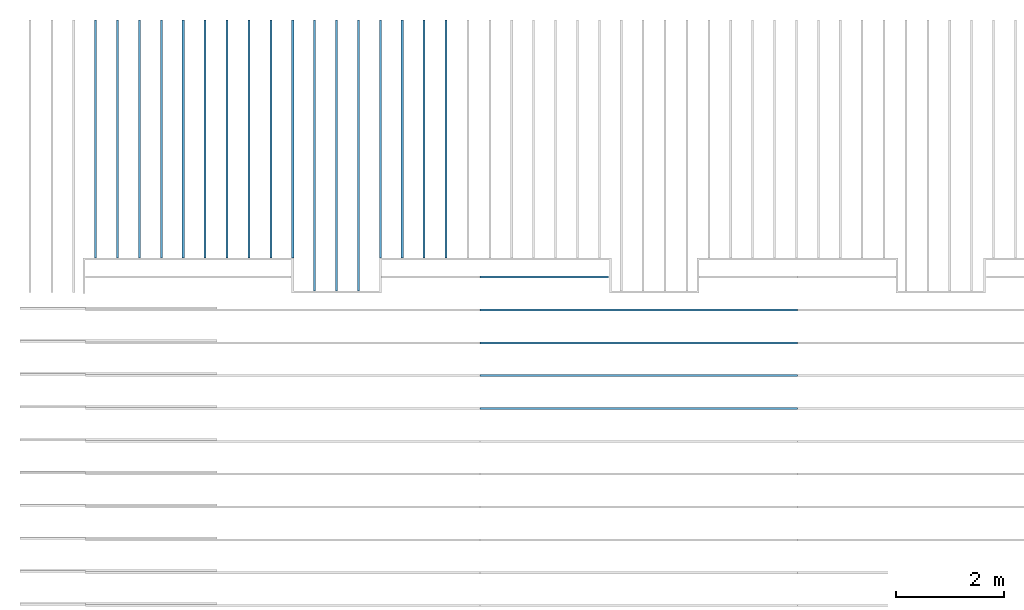
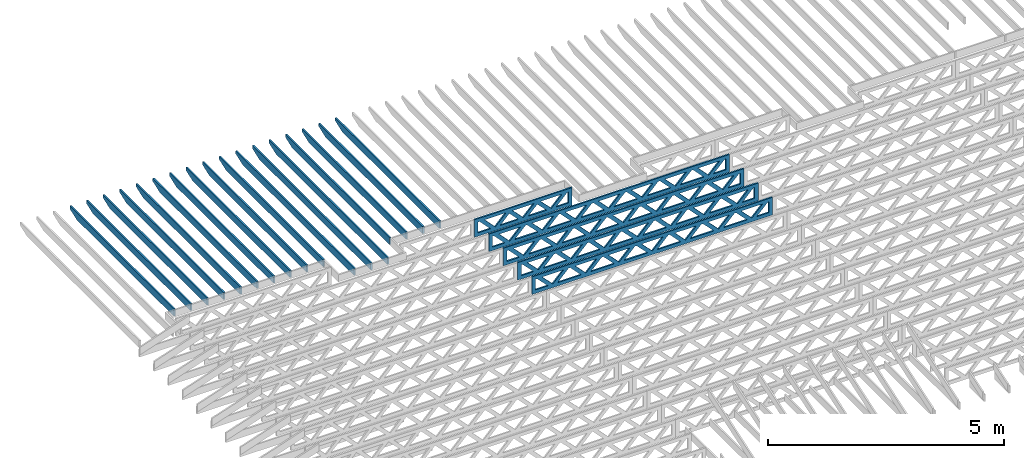
# One storey, part 5 of 18: 22 beams, 2 elements without a shape of their own.
"""IFC4 building model written with IfcOpenShell, lengths in feet."""

from ifc_helpers import new_model, entity, si_unit, converted_unit, derived_unit, direction, frame, frame_2d, origin, origin_2d_with_axis, place, context, subcontext, project, spatial, rectangle, extrude, clip, halfspace, source, transform, mapped, material, material_profile, profile_set, profile_usage, type_object, type_shapes, element, aggregate, save


model = new_model("IFC4")

# Units and contexts
model_context_1 = context("Model", 3, precision=0.0001, world=origin(), true_north=direction((6.12303176911189e-17, 1.0)))
model_context_2 = context("Model", 3, precision=0.0001, world=origin(), true_north=direction((6.12303176911189e-17, 1.0)))
body_context = subcontext(model_context_2, "Body", "Model", "MODEL_VIEW")
ifc_project = project(units=[converted_unit("LENGTHUNIT", "FOOT", entity("IfcRatioMeasure", 0.3048), si_unit("LENGTHUNIT", "METRE"), dimensions=[1, 0, 0, 0, 0, 0, 0]), converted_unit("AREAUNIT", "SQUARE FOOT", entity("IfcRatioMeasure", 0.09290304), si_unit("AREAUNIT", "SQUARE_METRE"), dimensions=[2, 0, 0, 0, 0, 0, 0]), converted_unit("VOLUMEUNIT", "CUBIC FOOT", entity("IfcRatioMeasure", 0.028316846592), si_unit("VOLUMEUNIT", "CUBIC_METRE"), dimensions=[3, 0, 0, 0, 0, 0, 0]), converted_unit("PLANEANGLEUNIT", "DEGREE", entity("IfcRatioMeasure", 0.0174532925199433), si_unit("PLANEANGLEUNIT", "RADIAN"), dimensions=[0, 0, 0, 0, 0, 0, 0]), si_unit("MASSUNIT", "GRAM", prefix="KILO"), derived_unit("MASSDENSITYUNIT", [(si_unit("MASSUNIT", "GRAM", prefix="KILO"), 1), (si_unit("LENGTHUNIT", "METRE"), -3)]), derived_unit("MOMENTOFINERTIAUNIT", [(si_unit("LENGTHUNIT", "METRE"), 4)]), si_unit("TIMEUNIT", "SECOND"), si_unit("FREQUENCYUNIT", "HERTZ"), si_unit("THERMODYNAMICTEMPERATUREUNIT", "DEGREE_CELSIUS"), derived_unit("THERMALTRANSMITTANCEUNIT", [(si_unit("MASSUNIT", "GRAM", prefix="KILO"), 1), (si_unit("THERMODYNAMICTEMPERATUREUNIT", "KELVIN"), -1), (si_unit("TIMEUNIT", "SECOND"), -3)]), derived_unit("VOLUMETRICFLOWRATEUNIT", [(si_unit("LENGTHUNIT", "METRE"), 3), (si_unit("TIMEUNIT", "SECOND"), -1)]), si_unit("ELECTRICCURRENTUNIT", "AMPERE"), si_unit("ELECTRICVOLTAGEUNIT", "VOLT"), si_unit("POWERUNIT", "WATT"), si_unit("FORCEUNIT", "NEWTON"), si_unit("ILLUMINANCEUNIT", "LUX"), si_unit("LUMINOUSFLUXUNIT", "LUMEN"), si_unit("LUMINOUSINTENSITYUNIT", "CANDELA"), derived_unit("USERDEFINED", [(si_unit("MASSUNIT", "GRAM", prefix="KILO"), -1), (si_unit("LENGTHUNIT", "METRE"), -2), (si_unit("TIMEUNIT", "SECOND"), 3), (si_unit("LUMINOUSFLUXUNIT", "LUMEN"), 1)]), derived_unit("LINEARVELOCITYUNIT", [(si_unit("LENGTHUNIT", "METRE"), 1), (si_unit("TIMEUNIT", "SECOND"), -1)]), si_unit("PRESSUREUNIT", "PASCAL"), derived_unit("USERDEFINED", [(si_unit("LENGTHUNIT", "METRE"), -2), (si_unit("MASSUNIT", "GRAM", prefix="KILO"), 1), (si_unit("TIMEUNIT", "SECOND"), -2)]), derived_unit("LINEARFORCEUNIT", [(si_unit("MASSUNIT", "GRAM", prefix="KILO"), 1), (si_unit("LENGTHUNIT", "METRE"), 1), (si_unit("TIMEUNIT", "SECOND"), -2), (si_unit("LENGTHUNIT", "METRE"), -1)]), derived_unit("PLANARFORCEUNIT", [(si_unit("MASSUNIT", "GRAM", prefix="KILO"), 1), (si_unit("LENGTHUNIT", "METRE"), 1), (si_unit("TIMEUNIT", "SECOND"), -2), (si_unit("LENGTHUNIT", "METRE"), -2)])], contexts=[model_context_1])

# Site, building, storey
site_placement = place(None, origin())
site = spatial("IfcSite", under=ifc_project, at=site_placement, CompositionType="ELEMENT")
building_placement = place(site_placement, origin())
building = spatial("IfcBuilding", under=site, at=building_placement, CompositionType="ELEMENT")
storey_placement = place(building_placement, frame((0.0, 0.0, 30.4375000000082)))
storey = spatial("IfcBuildingStorey", under=building, at=storey_placement, Name="ROOF", CompositionType="ELEMENT", Elevation=30.4375000000082)

# Assembly, beams
assembly_1_placement = place(storey_placement, origin())
assembly_1 = element("IfcElementAssembly", 1, at=assembly_1_placement, inside=storey, Name="Structural Beam System:Structural Framing System", ObjectType="Structural Beam System:Structural Framing System", AssemblyPlace="NOTDEFINED", PredefinedType="BEAM_GRID")
ifc_material_1 = material(Name="2X ROOF JOISTS - EXT. STAIN-1 - SEE LIFE SAFETY", Category="Materials")
ifc_material_profile_1 = material_profile(ifc_material_1, rectangle(XDim=0.604166666666667, YDim=0.125000000000011, at=frame_2d((0.0, 0.0), x_axis=(0.0, 1.0))))
ifc_profile_set_1 = profile_set([ifc_material_profile_1])
ifc_profile_usage_1 = profile_usage(ifc_profile_set_1, cardinal=8)
beam_type_1 = type_object("IfcBeamType", PredefinedType="BEAM", material=ifc_profile_set_1)
shared_shape_1 = source(origin(), body_context, "Body", "Clipping", [
    clip(extrude(rectangle(XDim=0.604166666666667, YDim=0.125000000000011, at=frame_2d((0.0, -5.55111512312578e-17), x_axis=(0.0, 1.0))), frame((-7.24296499610176, 0.0, 0.0), z_axis=(1.0, 0.0, 0.0), x_axis=(0.0, 1.0, 0.0)), (0.0, 0.0, 1.0), 14.4859299922035), halfspace(frame((-6.26990007671154, -0.0625000000000026, -0.30208333333334), z_axis=(-0.34202014332567, 0.0, -0.939692620785908), x_axis=(0.0, 1.0, 0.0)), False)),
])
type_shapes(beam_type_1, [shared_shape_1])
beam_1_placement = place(assembly_1_placement, frame((-261.133993818795, 966.271566032972, 1.07291666665844), z_axis=(0.0, 0.0, 1.0), x_axis=(0.0, -1.0, 0.0)))
beam_1 = element("IfcBeam", 2, at=beam_1_placement, type_object=beam_type_1, material=ifc_profile_usage_1, PredefinedType="BEAM", context=body_context, shape_type="MappedRepresentation", body=[
    mapped(shared_shape_1, transform((0.0, 0.0, 0.0), scale=1.0)),
])
ifc_profile_usage_2 = profile_usage(ifc_profile_set_1, cardinal=8)
beam_2_placement = place(assembly_1_placement, frame((-257.133993818795, 966.271566032972, 1.07291666665843), z_axis=(0.0, 0.0, 1.0), x_axis=(0.0, -1.0, 0.0)))
beam_2 = element("IfcBeam", 3, at=beam_2_placement, type_object=beam_type_1, material=ifc_profile_usage_2, PredefinedType="BEAM", context=body_context, shape_type="MappedRepresentation", body=[
    mapped(shared_shape_1, transform((0.0, 0.0, 0.0), scale=1.0)),
])
ifc_profile_usage_3 = profile_usage(ifc_profile_set_1, cardinal=8)
beam_3_placement = place(assembly_1_placement, frame((-254.467327152128, 966.271566032972, 1.07291666665842), z_axis=(0.0, 0.0, 1.0), x_axis=(0.0, -1.0, 0.0)))
beam_3 = element("IfcBeam", 4, at=beam_3_placement, type_object=beam_type_1, material=ifc_profile_usage_3, PredefinedType="BEAM", context=body_context, shape_type="MappedRepresentation", body=[
    mapped(shared_shape_1, transform((0.0, 0.0, 0.0), scale=1.0)),
])
ifc_profile_usage_4 = profile_usage(ifc_profile_set_1, cardinal=8)
beam_4_placement = place(assembly_1_placement, frame((-253.133993818795, 966.271566032972, 1.07291666665842), z_axis=(0.0, 0.0, 1.0), x_axis=(0.0, -1.0, 0.0)))
beam_4 = element("IfcBeam", 5, at=beam_4_placement, type_object=beam_type_1, material=ifc_profile_usage_4, PredefinedType="BEAM", context=body_context, shape_type="MappedRepresentation", body=[
    mapped(shared_shape_1, transform((0.0, 0.0, 0.0), scale=1.0)),
])
ifc_profile_usage_5 = profile_usage(ifc_profile_set_1, cardinal=8)
beam_5_placement = place(assembly_1_placement, frame((-255.800660485462, 966.271566032972, 1.07291666665843), z_axis=(0.0, 0.0, 1.0), x_axis=(0.0, -1.0, 0.0)))
beam_5 = element("IfcBeam", 6, at=beam_5_placement, type_object=beam_type_1, material=ifc_profile_usage_5, PredefinedType="BEAM", context=body_context, shape_type="MappedRepresentation", body=[
    mapped(shared_shape_1, transform((0.0, 0.0, 0.0), scale=1.0)),
])
ifc_profile_usage_6 = profile_usage(ifc_profile_set_1, cardinal=8)
beam_6_placement = place(assembly_1_placement, frame((-258.467327152129, 966.271566032972, 1.07291666665844), z_axis=(0.0, 0.0, 1.0), x_axis=(0.0, -1.0, 0.0)))
beam_6 = element("IfcBeam", 7, at=beam_6_placement, type_object=beam_type_1, material=ifc_profile_usage_6, PredefinedType="BEAM", context=body_context, shape_type="MappedRepresentation", body=[
    mapped(shared_shape_1, transform((0.0, 0.0, 0.0), scale=1.0)),
])
ifc_profile_usage_7 = profile_usage(ifc_profile_set_1, cardinal=8)
beam_7_placement = place(assembly_1_placement, frame((-259.800660485462, 966.271566032972, 1.07291666665844), z_axis=(0.0, 0.0, 1.0), x_axis=(0.0, -1.0, 0.0)))
beam_7 = element("IfcBeam", 8, at=beam_7_placement, type_object=beam_type_1, material=ifc_profile_usage_7, PredefinedType="BEAM", context=body_context, shape_type="MappedRepresentation", body=[
    mapped(shared_shape_1, transform((0.0, 0.0, 0.0), scale=1.0)),
])
ifc_profile_usage_8 = profile_usage(ifc_profile_set_1, cardinal=8)
beam_8_placement = place(assembly_1_placement, frame((-262.467327152129, 966.271566032972, 1.07291666665845), z_axis=(0.0, 0.0, 1.0), x_axis=(0.0, -1.0, 0.0)))
beam_8 = element("IfcBeam", 9, at=beam_8_placement, type_object=beam_type_1, material=ifc_profile_usage_8, PredefinedType="BEAM", context=body_context, shape_type="MappedRepresentation", body=[
    mapped(shared_shape_1, transform((0.0, 0.0, 0.0), scale=1.0)),
])
ifc_profile_usage_9 = profile_usage(ifc_profile_set_1, cardinal=8)
beam_9_placement = place(assembly_1_placement, frame((-263.800660485462, 966.271566032972, 1.07291666665845), z_axis=(0.0, 0.0, 1.0), x_axis=(0.0, -1.0, 0.0)))
beam_9 = element("IfcBeam", 10, at=beam_9_placement, type_object=beam_type_1, material=ifc_profile_usage_9, PredefinedType="BEAM", context=body_context, shape_type="MappedRepresentation", body=[
    mapped(shared_shape_1, transform((0.0, 0.0, 0.0), scale=1.0)),
])
ifc_profile_usage_10 = profile_usage(ifc_profile_set_1, cardinal=8)
beam_10_placement = place(assembly_1_placement, frame((-265.133993818795, 966.271566032972, 1.07291666665846), z_axis=(0.0, 0.0, 1.0), x_axis=(0.0, -1.0, 0.0)))
beam_10 = element("IfcBeam", 11, at=beam_10_placement, type_object=beam_type_1, material=ifc_profile_usage_10, PredefinedType="BEAM", context=body_context, shape_type="MappedRepresentation", body=[
    mapped(shared_shape_1, transform((0.0, 0.0, 0.0), scale=1.0)),
])
ifc_profile_usage_11 = profile_usage(ifc_profile_set_1, cardinal=8)
beam_type_2 = type_object("IfcBeamType", PredefinedType="BEAM", material=ifc_profile_set_1)
shared_shape_2 = source(origin(), body_context, "Body", "Clipping", [
    clip(extrude(rectangle(XDim=0.604166666666667, YDim=0.125000000000011, at=frame_2d((0.0, 0.0), x_axis=(0.0, 1.0))), frame((-8.24296473987818, 0.0, 0.0), z_axis=(1.0, 0.0, 0.0), x_axis=(0.0, 1.0, 0.0)), (0.0, 0.0, 1.0), 16.4859294797564), halfspace(frame((-7.26989982048795, -0.0625000000000026, -0.30208333333334), z_axis=(-0.34202014332567, 0.0, -0.939692620785908), x_axis=(0.0, 1.0, 0.0)), False)),
])
type_shapes(beam_type_2, [shared_shape_2])
beam_11_placement = place(assembly_1_placement, frame((-251.800660485462, 965.271566289195, 1.07291666665834), z_axis=(0.0, 0.0, 1.0), x_axis=(0.0, -1.0, 0.0)))
beam_11 = element("IfcBeam", 12, at=beam_11_placement, type_object=beam_type_2, material=ifc_profile_usage_11, PredefinedType="BEAM", context=body_context, shape_type="MappedRepresentation", body=[
    mapped(shared_shape_2, transform((0.0, 0.0, 0.0), scale=1.0)),
])
ifc_profile_usage_12 = profile_usage(ifc_profile_set_1, cardinal=8)
beam_12_placement = place(assembly_1_placement, frame((-250.467327152128, 965.271566289195, 1.07291666665834), z_axis=(0.0, 0.0, 1.0), x_axis=(0.0, -1.0, 0.0)))
beam_12 = element("IfcBeam", 13, at=beam_12_placement, type_object=beam_type_2, material=ifc_profile_usage_12, PredefinedType="BEAM", context=body_context, shape_type="MappedRepresentation", body=[
    mapped(shared_shape_2, transform((0.0, 0.0, 0.0), scale=1.0)),
])
ifc_profile_usage_13 = profile_usage(ifc_profile_set_1, cardinal=8)
beam_13_placement = place(assembly_1_placement, frame((-249.133993818795, 965.271566289195, 1.07291666665834), z_axis=(0.0, 0.0, 1.0), x_axis=(0.0, -1.0, 0.0)))
beam_13 = element("IfcBeam", 14, at=beam_13_placement, type_object=beam_type_2, material=ifc_profile_usage_13, PredefinedType="BEAM", context=body_context, shape_type="MappedRepresentation", body=[
    mapped(shared_shape_2, transform((0.0, 0.0, 0.0), scale=1.0)),
])
ifc_profile_usage_14 = profile_usage(ifc_profile_set_1, cardinal=8)
beam_type_3 = type_object("IfcBeamType", PredefinedType="BEAM", material=ifc_profile_set_1)
shared_shape_3 = source(origin(), body_context, "Body", "Clipping", [
    clip(extrude(rectangle(XDim=0.604166666666667, YDim=0.125000000000011, at=frame_2d((0.0, 0.0), x_axis=(0.0, 1.0))), frame((-7.24296333718945, 0.0, 0.0), z_axis=(1.0, 0.0, 0.0), x_axis=(0.0, 1.0, 0.0)), (0.0, 0.0, 1.0), 14.4859266743789), halfspace(frame((-6.26989841779922, -0.0625000000000026, -0.30208333333334), z_axis=(-0.34202014332567, 0.0, -0.939692620785908), x_axis=(0.0, 1.0, 0.0)), False)),
])
type_shapes(beam_type_3, [shared_shape_3])
beam_14_placement = place(assembly_1_placement, frame((-247.800660485462, 966.271567691884, 1.07291666665834), z_axis=(0.0, 0.0, 1.0), x_axis=(0.0, -1.0, 0.0)))
beam_14 = element("IfcBeam", 15, at=beam_14_placement, type_object=beam_type_3, material=ifc_profile_usage_14, PredefinedType="BEAM", context=body_context, shape_type="MappedRepresentation", body=[
    mapped(shared_shape_3, transform((0.0, 0.0, 0.0), scale=1.0)),
])
ifc_profile_usage_15 = profile_usage(ifc_profile_set_1, cardinal=8)
beam_type_4 = type_object("IfcBeamType", PredefinedType="BEAM", material=ifc_profile_set_1)
shared_shape_4 = source(origin(), body_context, "Body", "Clipping", [
    clip(extrude(rectangle(XDim=0.604166666666667, YDim=0.125000000000011, at=frame_2d((0.0, 0.0), x_axis=(0.0, 1.0))), frame((-7.24296367016814, 0.0, 0.0), z_axis=(1.0, 0.0, 0.0), x_axis=(0.0, 1.0, 0.0)), (0.0, 0.0, 1.0), 14.4859273403363), halfspace(frame((-6.26989875077791, -0.0625000000000026, -0.30208333333334), z_axis=(-0.34202014332567, 0.0, -0.939692620785908), x_axis=(0.0, 1.0, 0.0)), False)),
])
type_shapes(beam_type_4, [shared_shape_4])
beam_15_placement = place(assembly_1_placement, frame((-245.133993818795, 966.271567356882, 1.07291666665833), z_axis=(0.0, 0.0, 1.0), x_axis=(0.0, -1.0, 0.0)))
beam_15 = element("IfcBeam", 16, at=beam_15_placement, type_object=beam_type_4, material=ifc_profile_usage_15, PredefinedType="BEAM", context=body_context, shape_type="MappedRepresentation", body=[
    mapped(shared_shape_4, transform((0.0, 0.0, 0.0), scale=1.0)),
])
ifc_profile_usage_16 = profile_usage(ifc_profile_set_1, cardinal=8)
beam_type_5 = type_object("IfcBeamType", PredefinedType="BEAM", material=ifc_profile_set_1)
shared_shape_5 = source(origin(), body_context, "Body", "Clipping", [
    clip(extrude(rectangle(XDim=0.604166666666667, YDim=0.125000000000011, at=frame_2d((0.0, 0.0), x_axis=(0.0, 1.0))), frame((-7.24296351885744, 0.0, 0.0), z_axis=(1.0, 0.0, 0.0), x_axis=(0.0, 1.0, 0.0)), (0.0, 0.0, 1.0), 14.4859270377149), halfspace(frame((-6.26989859946721, -0.0625000000000026, -0.30208333333334), z_axis=(-0.34202014332567, 0.0, -0.939692620785908), x_axis=(0.0, 1.0, 0.0)), False)),
])
type_shapes(beam_type_5, [shared_shape_5])
beam_16_placement = place(assembly_1_placement, frame((-246.467327152128, 966.271567524383, 1.07291666665834), z_axis=(0.0, 0.0, 1.0), x_axis=(0.0, -1.0, 0.0)))
beam_16 = element("IfcBeam", 17, at=beam_16_placement, type_object=beam_type_5, material=ifc_profile_usage_16, PredefinedType="BEAM", context=body_context, shape_type="MappedRepresentation", body=[
    mapped(shared_shape_5, transform((0.0, 0.0, 0.0), scale=1.0)),
])
ifc_profile_usage_17 = profile_usage(ifc_profile_set_1, cardinal=8)
beam_type_6 = type_object("IfcBeamType", PredefinedType="BEAM", material=ifc_profile_set_1)
shared_shape_6 = source(origin(), body_context, "Body", "Clipping", [
    clip(extrude(rectangle(XDim=0.604166666666667, YDim=0.125000000000011, at=frame_2d((0.0, 0.0), x_axis=(0.0, 1.0))), frame((-7.24296383969306, 0.0, 0.0), z_axis=(1.0, 0.0, 0.0), x_axis=(0.0, 1.0, 0.0)), (0.0, 0.0, 1.0), 14.4859276793861), halfspace(frame((-6.26989892030283, -0.0625000000000026, -0.30208333333334), z_axis=(-0.34202014332567, 0.0, -0.939692620785908), x_axis=(0.0, 1.0, 0.0)), False)),
])
type_shapes(beam_type_6, [shared_shape_6])
beam_17_placement = place(assembly_1_placement, frame((-243.800660485462, 966.27156718938, 1.07291666665833), z_axis=(0.0, 0.0, 1.0), x_axis=(0.0, -1.0, 0.0)))
beam_17 = element("IfcBeam", 18, at=beam_17_placement, type_object=beam_type_6, material=ifc_profile_usage_17, PredefinedType="BEAM", context=body_context, shape_type="MappedRepresentation", body=[
    mapped(shared_shape_6, transform((0.0, 0.0, 0.0), scale=1.0)),
])
aggregate(assembly_1, [beam_1, beam_2, beam_3, beam_4, beam_11, beam_12, beam_14, beam_15, beam_17, beam_16, beam_13, beam_5, beam_6, beam_7, beam_8, beam_9, beam_10])

assembly_2_placement = place(storey_placement, origin())
assembly_2 = element("IfcElementAssembly", 19, at=assembly_2_placement, inside=storey, Name="Structural Beam System:Structural Framing System", ObjectType="Structural Beam System:Structural Framing System", AssemblyPlace="NOTDEFINED", PredefinedType="BEAM_GRID")
ifc_material_2 = material(Name="WOOD TRUSS", Category="Materials")
ifc_material_profile_2 = material_profile(ifc_material_2, rectangle(XDim=1.73473973950632, YDim=0.125, at=origin_2d_with_axis()))
ifc_material_profile_3 = material_profile(ifc_material_2, rectangle(XDim=1.73473973950633, YDim=0.125, at=frame_2d((-1.11022302462516e-16, 0.0), x_axis=(1.0, 0.0))))
ifc_material_profile_4 = material_profile(ifc_material_2, rectangle(XDim=1.73473973950632, YDim=0.125, at=origin_2d_with_axis()))
ifc_material_profile_5 = material_profile(ifc_material_2, rectangle(XDim=1.73473973950633, YDim=0.125, at=origin_2d_with_axis()))
ifc_material_profile_6 = material_profile(ifc_material_2, rectangle(XDim=1.73473973950632, YDim=0.125, at=frame_2d((-5.55111512312578e-17, 0.0), x_axis=(1.0, 0.0))))
ifc_material_profile_7 = material_profile(ifc_material_2, rectangle(XDim=1.73473973950633, YDim=0.125, at=frame_2d((-2.77555756156289e-16, 0.0), x_axis=(1.0, 0.0))))
ifc_material_profile_8 = material_profile(ifc_material_2, rectangle(XDim=1.73473973950632, YDim=0.125, at=frame_2d((-4.9960036108132e-16, 0.0), x_axis=(1.0, 0.0))))
ifc_material_profile_9 = material_profile(ifc_material_2, rectangle(XDim=1.73473973950633, YDim=0.125, at=frame_2d((4.44089209850063e-16, 0.0), x_axis=(1.0, 0.0))))
ifc_material_profile_10 = material_profile(ifc_material_2, rectangle(XDim=1.73473973950632, YDim=0.125, at=origin_2d_with_axis()))
ifc_material_profile_11 = material_profile(ifc_material_2, rectangle(XDim=1.73473973950633, YDim=0.125, at=frame_2d((-4.9960036108132e-16, 0.0), x_axis=(1.0, 0.0))))
ifc_material_profile_12 = material_profile(ifc_material_2, rectangle(XDim=0.291666666666664, YDim=0.125, at=frame_2d((-2.77555756156289e-17, 0.0), x_axis=(1.0, 0.0))))
ifc_material_profile_13 = material_profile(ifc_material_2, rectangle(XDim=0.291666666666628, YDim=0.124999999999995, at=frame_2d((-5.55111512312578e-17, 0.0), x_axis=(1.0, 0.0))))
ifc_material_profile_14 = material_profile(ifc_material_2, rectangle(XDim=0.916666666666666, YDim=0.125000000000003, at=frame_2d((-2.77555756156289e-17, 0.0), x_axis=(1.0, 0.0))))
ifc_material_profile_15 = material_profile(ifc_material_2, rectangle(XDim=0.916666666666651, YDim=0.125, at=frame_2d((-2.77555756156289e-17, 0.0), x_axis=(1.0, 0.0))))
ifc_profile_set_2 = profile_set([ifc_material_profile_2, ifc_material_profile_3, ifc_material_profile_4, ifc_material_profile_5, ifc_material_profile_6, ifc_material_profile_7, ifc_material_profile_8, ifc_material_profile_9, ifc_material_profile_10, ifc_material_profile_11, ifc_material_profile_12, ifc_material_profile_13, ifc_material_profile_14, ifc_material_profile_15])
ifc_profile_usage_18 = profile_usage(ifc_profile_set_2, cardinal=8)
beam_type_7 = type_object("IfcBeamType", PredefinedType="BEAM", material=ifc_profile_set_2)
shared_shape_7 = source(origin(), body_context, "Body", "SweptSolid", [
    extrude(rectangle(XDim=1.73473973950632, YDim=0.125, at=frame_2d((-5.55111512312578e-16, 0.0), x_axis=(1.0, 0.0))), frame((5.85339326404794, 0.0, 0.101118361020562), z_axis=(0.720569184836762, 0.0, -0.693383046997606), x_axis=(0.693383046997606, 0.0, 0.720569184836762)), (0.0, 0.0, 1.0), 0.291666666666667),
    extrude(rectangle(XDim=1.73473973950633, YDim=0.125, at=frame_2d((-4.9960036108132e-16, 0.0), x_axis=(1.0, 0.0))), frame((4.60310739037467, 0.0, -0.101118361020407), z_axis=(0.720569184836758, 0.0, 0.69338304699761), x_axis=(0.69338304699761, 0.0, -0.720569184836758)), (0.0, 0.0, 1.0), 0.291666666666667),
    extrude(rectangle(XDim=1.73473973950632, YDim=0.125, at=frame_2d((3.33066907387547e-16, 0.0), x_axis=(1.0, 0.0))), frame((3.18672659738144, 0.0, 0.101118361020562), z_axis=(0.720569184836762, 0.0, -0.693383046997606), x_axis=(0.693383046997606, 0.0, 0.720569184836762)), (0.0, 0.0, 1.0), 0.291666666666667),
    extrude(rectangle(XDim=1.73473973950633, YDim=0.125, at=frame_2d((-1.11022302462516e-16, 0.0), x_axis=(1.0, 0.0))), frame((1.93644072370817, 0.0, -0.101118361020407), z_axis=(0.720569184836758, 0.0, 0.69338304699761), x_axis=(0.69338304699761, 0.0, -0.720569184836758)), (0.0, 0.0, 1.0), 0.291666666666666),
    extrude(rectangle(XDim=1.73473973950632, YDim=0.125, at=frame_2d((5.55111512312578e-17, 0.0), x_axis=(1.0, 0.0))), frame((0.520059930714937, 0.0, 0.101118361020562), z_axis=(0.720569184836762, 0.0, -0.693383046997606), x_axis=(0.693383046997606, 0.0, 0.720569184836762)), (0.0, 0.0, 1.0), 0.291666666666667),
    extrude(rectangle(XDim=1.73473973950633, YDim=0.125, at=origin_2d_with_axis()), frame((-0.730225942958334, 0.0, -0.101118361020407), z_axis=(0.720569184836758, 0.0, 0.69338304699761), x_axis=(0.69338304699761, 0.0, -0.720569184836758)), (0.0, 0.0, 1.0), 0.291666666666666),
    extrude(rectangle(XDim=1.73473973950632, YDim=0.125, at=frame_2d((-5.55111512312578e-17, 0.0), x_axis=(1.0, 0.0))), frame((-2.14660673595157, 0.0, 0.101118361020562), z_axis=(0.720569184836762, 0.0, -0.693383046997606), x_axis=(0.693383046997606, 0.0, 0.720569184836762)), (0.0, 0.0, 1.0), 0.291666666666667),
    extrude(rectangle(XDim=1.73473973950633, YDim=0.125, at=frame_2d((-2.77555756156289e-16, 0.0), x_axis=(1.0, 0.0))), frame((-3.39689260962484, 0.0, -0.101118361020407), z_axis=(0.720569184836758, 0.0, 0.69338304699761), x_axis=(0.69338304699761, 0.0, -0.720569184836758)), (0.0, 0.0, 1.0), 0.291666666666666),
    extrude(rectangle(XDim=1.73473973950632, YDim=0.125, at=origin_2d_with_axis()), frame((-4.81327340261807, 0.0, 0.101118361020562), z_axis=(0.720569184836762, 0.0, -0.693383046997606), x_axis=(0.693383046997606, 0.0, 0.720569184836762)), (0.0, 0.0, 1.0), 0.291666666666667),
    extrude(rectangle(XDim=1.73473973950633, YDim=0.125, at=frame_2d((-4.9960036108132e-16, 0.0), x_axis=(1.0, 0.0))), frame((-6.06355927629134, 0.0, -0.101118361020407), z_axis=(0.720569184836758, 0.0, 0.69338304699761), x_axis=(0.69338304699761, 0.0, -0.720569184836758)), (0.0, 0.0, 1.0), 0.291666666666667),
    extrude(rectangle(XDim=1.73473973950632, YDim=0.125, at=frame_2d((-1.0547118733939e-15, 0.0), x_axis=(1.0, 0.0))), frame((8.52005993071445, 0.0, 0.101118361020506), z_axis=(0.720569184836761, 0.0, -0.693383046997607), x_axis=(0.693383046997607, 0.0, 0.720569184836761)), (0.0, 0.0, 1.0), 0.291666666666667),
    extrude(rectangle(XDim=1.73473973950633, YDim=0.125, at=origin_2d_with_axis()), frame((7.26977405704118, 0.0, -0.101118361020463), z_axis=(0.720569184836758, 0.0, 0.69338304699761), x_axis=(0.69338304699761, 0.0, -0.720569184836758)), (0.0, 0.0, 1.0), 0.291666666666667),
    extrude(rectangle(XDim=1.73473973950632, YDim=0.125, at=frame_2d((4.44089209850063e-16, 0.0), x_axis=(1.0, 0.0))), frame((-7.47994006928457, 0.0, 0.101118361020561), z_axis=(0.720569184836762, 0.0, -0.693383046997606), x_axis=(0.693383046997606, 0.0, 0.720569184836762)), (0.0, 0.0, 1.0), 0.291666666666666),
    extrude(rectangle(XDim=1.73473973950633, YDim=0.125, at=origin_2d_with_axis()), frame((-8.73022594295784, 0.0, -0.101118361020408), z_axis=(0.720569184836758, 0.0, 0.69338304699761), x_axis=(0.69338304699761, 0.0, -0.720569184836758)), (0.0, 0.0, 1.0), 0.291666666666666),
    extrude(rectangle(XDim=0.291666666666664, YDim=0.125, at=frame_2d((-2.77555756156289e-17, 0.0), x_axis=(1.0, 0.0))), frame((-9.66666666666609, 0.0, 0.604166666666611), z_axis=(1.0, 0.0, 0.0), x_axis=(0.0, 0.0, -1.0)), (0.0, 0.0, 1.0), 19.3333333333322),
    extrude(rectangle(XDim=0.291666666666628, YDim=0.124999999999995, at=frame_2d((-5.55111512312578e-17, 0.0), x_axis=(1.0, 0.0))), frame((-9.66666666666588, 0.0, -0.604166666666693), z_axis=(1.0, 0.0, 0.0), x_axis=(0.0, 0.0, -1.0)), (0.0, 0.0, 1.0), 19.333333333332),
    extrude(rectangle(XDim=0.916666666666666, YDim=0.125000000000003, at=frame_2d((-2.77555756156289e-17, 0.0), x_axis=(1.0, 0.0))), frame((9.3749999999994, 0.0, 0.0), z_axis=(1.0, 0.0, 0.0), x_axis=(0.0, 0.0, -1.0)), (0.0, 0.0, 1.0), 0.291666666666687),
    extrude(rectangle(XDim=0.916666666666651, YDim=0.125, at=frame_2d((-2.77555756156289e-17, 0.0), x_axis=(1.0, 0.0))), frame((-9.66666666666609, 0.0, 0.0), z_axis=(1.0, 0.0, 0.0), x_axis=(0.0, 0.0, -1.0)), (0.0, 0.0, 1.0), 0.291666666666687),
])
type_shapes(beam_type_7, [shared_shape_7])
beam_18_placement = place(assembly_2_placement, frame((-232.071493818828, 949.861934882651, 0.749999999991623)))
beam_18 = element("IfcBeam", 20, at=beam_18_placement, type_object=beam_type_7, material=ifc_profile_usage_18, PredefinedType="BEAM", context=body_context, shape_type="MappedRepresentation", body=[
    mapped(shared_shape_7, transform((0.0, 0.0, 0.0), scale=1.0)),
])
ifc_profile_usage_19 = profile_usage(ifc_profile_set_2, cardinal=8)
beam_19_placement = place(assembly_2_placement, frame((-232.071493818828, 951.861934882651, 0.749999999991623)))
beam_19 = element("IfcBeam", 21, at=beam_19_placement, type_object=beam_type_7, material=ifc_profile_usage_19, PredefinedType="BEAM", context=body_context, shape_type="MappedRepresentation", body=[
    mapped(shared_shape_7, transform((0.0, 0.0, 0.0), scale=1.0)),
])
ifc_profile_usage_20 = profile_usage(ifc_profile_set_2, cardinal=8)
beam_20_placement = place(assembly_2_placement, frame((-232.071493818828, 953.861934882651, 0.749999999991616)))
beam_20 = element("IfcBeam", 22, at=beam_20_placement, type_object=beam_type_7, material=ifc_profile_usage_20, PredefinedType="BEAM", context=body_context, shape_type="MappedRepresentation", body=[
    mapped(shared_shape_7, transform((0.0, 0.0, 0.0), scale=1.0)),
])
ifc_profile_usage_21 = profile_usage(ifc_profile_set_2, cardinal=8)
beam_21_placement = place(assembly_2_placement, frame((-232.071493818828, 955.861934882651, 0.749999999991608)))
beam_21 = element("IfcBeam", 23, at=beam_21_placement, type_object=beam_type_7, material=ifc_profile_usage_21, PredefinedType="BEAM", context=body_context, shape_type="MappedRepresentation", body=[
    mapped(shared_shape_7, transform((0.0, 0.0, 0.0), scale=1.0)),
])
ifc_profile_usage_22 = profile_usage(ifc_profile_set_2, cardinal=8)
beam_type_8 = type_object("IfcBeamType", PredefinedType="BEAM", material=ifc_profile_set_2)
shared_shape_8 = source(origin(), body_context, "Body", "SweptSolid", [
    extrude(rectangle(XDim=1.73473973950632, YDim=0.125, at=origin_2d_with_axis()), frame((0.520059930714934, 0.0, 0.101118361020562), z_axis=(0.720569184836762, 0.0, -0.693383046997606), x_axis=(0.693383046997606, 0.0, 0.720569184836762)), (0.0, 0.0, 1.0), 0.291666666666667),
    extrude(rectangle(XDim=1.73473973950633, YDim=0.125, at=origin_2d_with_axis()), frame((-0.730225942958336, 0.0, -0.101118361020407), z_axis=(0.720569184836758, 0.0, 0.69338304699761), x_axis=(0.69338304699761, 0.0, -0.720569184836758)), (0.0, 0.0, 1.0), 0.291666666666666),
    extrude(rectangle(XDim=1.73473973950632, YDim=0.125, at=origin_2d_with_axis()), frame((2.77005983191593, 0.0, 0.101118361020514), z_axis=(0.720569184836762, 0.0, -0.693383046997606), x_axis=(0.693383046997606, 0.0, 0.720569184836762)), (0.0, 0.0, 1.0), 0.291666666666667),
    extrude(rectangle(XDim=1.73473973950633, YDim=0.125, at=frame_2d((-1.11022302462516e-16, 0.0), x_axis=(1.0, 0.0))), frame((1.51977395824266, 0.0, -0.101118361020455), z_axis=(0.720569184836758, 0.0, 0.69338304699761), x_axis=(0.69338304699761, 0.0, -0.720569184836758)), (0.0, 0.0, 1.0), 0.291666666666666),
    extrude(rectangle(XDim=1.73473973950632, YDim=0.125, at=frame_2d((-5.55111512312578e-17, 0.0), x_axis=(1.0, 0.0))), frame((-1.72993997048606, 0.0, 0.101118361020555), z_axis=(0.720569184836762, 0.0, -0.693383046997606), x_axis=(0.693383046997606, 0.0, 0.720569184836762)), (0.0, 0.0, 1.0), 0.291666666666667),
    extrude(rectangle(XDim=1.73473973950633, YDim=0.125, at=frame_2d((-2.77555756156289e-16, 0.0), x_axis=(1.0, 0.0))), frame((-2.98022584415933, 0.0, -0.101118361020414), z_axis=(0.720569184836758, 0.0, 0.69338304699761), x_axis=(0.69338304699761, 0.0, -0.720569184836758)), (0.0, 0.0, 1.0), 0.291666666666666),
    extrude(rectangle(XDim=0.291666666666664, YDim=0.125, at=frame_2d((-2.77555756156289e-17, 0.0), x_axis=(1.0, 0.0))), frame((-3.91666656786758, 0.0, 0.604166666666611), z_axis=(1.0, 0.0, 0.0), x_axis=(0.0, 0.0, -1.0)), (0.0, 0.0, 1.0), 7.83333313573516),
    extrude(rectangle(XDim=0.291666666666628, YDim=0.124999999999995, at=frame_2d((-5.55111512312578e-17, 0.0), x_axis=(1.0, 0.0))), frame((-3.91666656786737, 0.0, -0.604166666666693), z_axis=(1.0, 0.0, 0.0), x_axis=(0.0, 0.0, -1.0)), (0.0, 0.0, 1.0), 7.83333313573495),
    extrude(rectangle(XDim=0.916666666666666, YDim=0.125000000000003, at=frame_2d((-2.77555756156289e-17, 0.0), x_axis=(1.0, 0.0))), frame((3.62499990120089, 0.0, 0.0), z_axis=(1.0, 0.0, 0.0), x_axis=(0.0, 0.0, -1.0)), (0.0, 0.0, 1.0), 0.291666666666687),
    extrude(rectangle(XDim=0.916666666666651, YDim=0.125, at=frame_2d((-2.77555756156289e-17, 0.0), x_axis=(1.0, 0.0))), frame((-3.91666656786758, 0.0, 0.0), z_axis=(1.0, 0.0, 0.0), x_axis=(0.0, 0.0, -1.0)), (0.0, 0.0, 1.0), 0.291666666666687),
])
type_shapes(beam_type_8, [shared_shape_8])
beam_22_placement = place(assembly_2_placement, frame((-237.821493917626, 957.861934882651, 0.749999999991608)))
beam_22 = element("IfcBeam", 24, at=beam_22_placement, type_object=beam_type_8, material=ifc_profile_usage_22, PredefinedType="BEAM", context=body_context, shape_type="MappedRepresentation", body=[
    mapped(shared_shape_8, transform((0.0, 0.0, 0.0), scale=1.0)),
])
aggregate(assembly_2, [beam_18, beam_19, beam_20, beam_21, beam_22])

save(model, "model.ifc")
